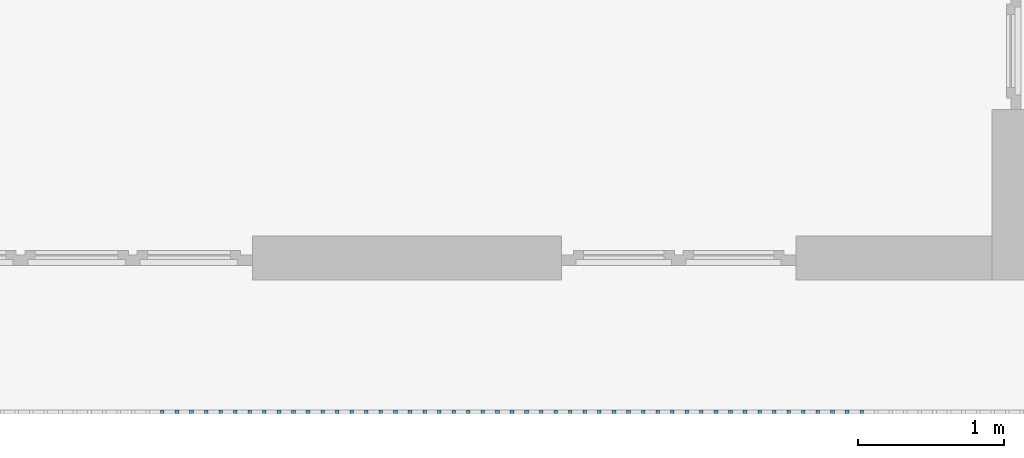
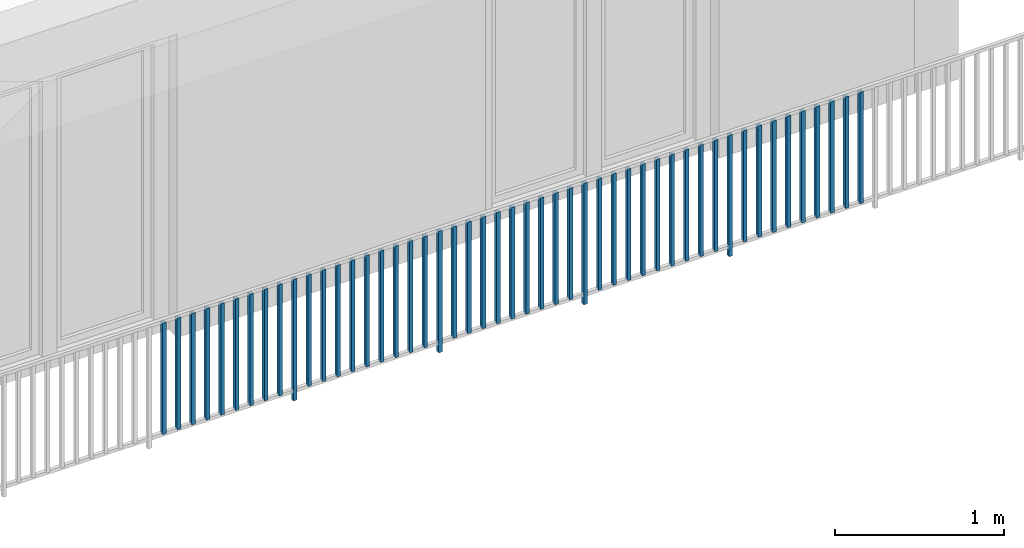
# One storey, part 36 of 48: 49 building element parts, 1 element without a shape of its own.
"""IFC4 building model written with IfcOpenShell, lengths in metres."""

from ifc_helpers import new_model, entity, si_unit, converted_unit, derived_unit, direction, frame, origin_with_axes, place, context, subcontext, project, spatial, polygons, material, type_object, element, aggregate, save


model = new_model("IFC4")

# Units and contexts
model_context = context("Model", 3, precision=1e-05, world=origin_with_axes(), true_north=direction((0.0, 1.0)))
body_context = subcontext(model_context, "Body", "Model", "MODEL_VIEW")
ifc_project = project(units=[si_unit("LENGTHUNIT", "METRE"), si_unit("AREAUNIT", "SQUARE_METRE"), si_unit("VOLUMEUNIT", "CUBIC_METRE"), converted_unit("PLANEANGLEUNIT", "DEGREE", entity("IfcPlaneAngleMeasure", 0.0174532925199), si_unit("PLANEANGLEUNIT", "RADIAN"), dimensions=[0, 0, 0, 0, 0, 0, 0]), converted_unit("TIMEUNIT", "Year", entity("IfcTimeMeasure", 31556926.0), si_unit("TIMEUNIT", "SECOND"), dimensions=[0, 0, 1, 0, 0, 0, 0]), si_unit("MASSUNIT", "GRAM", prefix="KILO"), si_unit("THERMODYNAMICTEMPERATUREUNIT", "DEGREE_CELSIUS"), si_unit("LUMINOUSINTENSITYUNIT", "LUMEN"), si_unit("ENERGYUNIT", "JOULE", prefix="MEGA"), derived_unit("THERMALCONDUCTANCEUNIT", [(si_unit("POWERUNIT", "WATT"), 1), (si_unit("LENGTHUNIT", "METRE"), -1), (si_unit("THERMODYNAMICTEMPERATUREUNIT", "KELVIN"), -1)]), derived_unit("SPECIFICHEATCAPACITYUNIT", [(si_unit("ENERGYUNIT", "JOULE"), 1), (si_unit("MASSUNIT", "GRAM", prefix="KILO"), -1), (si_unit("THERMODYNAMICTEMPERATUREUNIT", "KELVIN"), -1)]), derived_unit("MASSDENSITYUNIT", [(si_unit("MASSUNIT", "GRAM", prefix="KILO"), 1), (si_unit("VOLUMEUNIT", "CUBIC_METRE"), -1)])], contexts=[model_context])

# Site, building, storey
site_placement = place(None, origin_with_axes())
site = spatial("IfcSite", under=ifc_project, at=site_placement, CompositionType="ELEMENT")
building_placement = place(site_placement, origin_with_axes())
building = spatial("IfcBuilding", under=site, at=building_placement, CompositionType="ELEMENT")
storey_placement = place(building_placement, frame((0.0, 0.0, 3.4), z_axis=(0.0, 0.0, 1.0), x_axis=(1.0, 0.0, 0.0)))
storey = spatial("IfcBuildingStorey", under=building, at=storey_placement, Name="1. Geschoss", CompositionType="ELEMENT", Elevation=3.4)

# Railing, building element parts
railing_type = type_object("IfcRailingType", PredefinedType="NOTDEFINED")
railing_placement = place(storey_placement, frame((10.2378006196, 9.82118776896, 0.0), z_axis=(0.0, 0.0, 1.0), x_axis=(1.0, 0.0, 0.0)))
railing = element("IfcRailing", 1, at=railing_placement, inside=storey, type_object=railing_type, PredefinedType="NOTDEFINED")
ifc_material = material()
building_element_part_1_placement = place(railing_placement, origin_with_axes())
building_element_part_1 = element("IfcBuildingElementPart", 2, at=building_element_part_1_placement, material=ifc_material, PredefinedType="NOTDEFINED", context=body_context, shape_type="Tessellation", body=[
    polygons([(-6.8515, -20.6625, 0.07), (-6.8515, -20.6375, 0.07), (-6.8515, -20.6375, 0.8775), (-6.8515, -20.6625, 0.8775), (-6.8765, -20.6625, 0.07), (-6.8765, -20.6375, 0.07), (-6.8765, -20.6375, 0.8775), (-6.8765, -20.6625, 0.8775)], [[[1, 2, 3, 4]], [[1, 5, 6, 2]], [[2, 6, 7, 3]], [[4, 3, 7, 8]], [[5, 1, 4, 8]], [[6, 5, 8, 7]]], closed=True),
])
building_element_part_2_placement = place(railing_placement, origin_with_axes())
building_element_part_2 = element("IfcBuildingElementPart", 3, at=building_element_part_2_placement, material=ifc_material, PredefinedType="NOTDEFINED", context=body_context, shape_type="Tessellation", body=[
    polygons([(-6.75202173913, -20.6625, 0.07), (-6.75202173913, -20.6375, 0.07), (-6.75202173913, -20.6375, 0.8775), (-6.75202173913, -20.6625, 0.8775), (-6.77702173913, -20.6625, 0.07), (-6.77702173913, -20.6375, 0.07), (-6.77702173913, -20.6375, 0.8775), (-6.77702173913, -20.6625, 0.8775)], [[[1, 2, 3, 4]], [[1, 5, 6, 2]], [[2, 6, 7, 3]], [[4, 3, 7, 8]], [[5, 1, 4, 8]], [[6, 5, 8, 7]]], closed=True),
])
building_element_part_3_placement = place(railing_placement, origin_with_axes())
building_element_part_3 = element("IfcBuildingElementPart", 4, at=building_element_part_3_placement, material=ifc_material, PredefinedType="NOTDEFINED", context=body_context, shape_type="Tessellation", body=[
    polygons([(-6.65254347826, -20.6625, 0.07), (-6.65254347826, -20.6375, 0.07), (-6.65254347826, -20.6375, 0.8775), (-6.65254347826, -20.6625, 0.8775), (-6.67754347826, -20.6625, 0.07), (-6.67754347826, -20.6375, 0.07), (-6.67754347826, -20.6375, 0.8775), (-6.67754347826, -20.6625, 0.8775)], [[[1, 2, 3, 4]], [[1, 5, 6, 2]], [[2, 6, 7, 3]], [[4, 3, 7, 8]], [[5, 1, 4, 8]], [[6, 5, 8, 7]]], closed=True),
])
building_element_part_4_placement = place(railing_placement, origin_with_axes())
building_element_part_4 = element("IfcBuildingElementPart", 5, at=building_element_part_4_placement, material=ifc_material, PredefinedType="NOTDEFINED", context=body_context, shape_type="Tessellation", body=[
    polygons([(-6.55306521739, -20.6625, 0.07), (-6.55306521739, -20.6375, 0.07), (-6.55306521739, -20.6375, 0.8775), (-6.55306521739, -20.6625, 0.8775), (-6.57806521739, -20.6625, 0.07), (-6.57806521739, -20.6375, 0.07), (-6.57806521739, -20.6375, 0.8775), (-6.57806521739, -20.6625, 0.8775)], [[[1, 2, 3, 4]], [[1, 5, 6, 2]], [[2, 6, 7, 3]], [[4, 3, 7, 8]], [[5, 1, 4, 8]], [[6, 5, 8, 7]]], closed=True),
])
building_element_part_5_placement = place(railing_placement, origin_with_axes())
building_element_part_5 = element("IfcBuildingElementPart", 6, at=building_element_part_5_placement, material=ifc_material, PredefinedType="NOTDEFINED", context=body_context, shape_type="Tessellation", body=[
    polygons([(-6.45358695652, -20.6625, 0.07), (-6.45358695652, -20.6375, 0.07), (-6.45358695652, -20.6375, 0.8775), (-6.45358695652, -20.6625, 0.8775), (-6.47858695652, -20.6625, 0.07), (-6.47858695652, -20.6375, 0.07), (-6.47858695652, -20.6375, 0.8775), (-6.47858695652, -20.6625, 0.8775)], [[[1, 2, 3, 4]], [[1, 5, 6, 2]], [[2, 6, 7, 3]], [[4, 3, 7, 8]], [[5, 1, 4, 8]], [[6, 5, 8, 7]]], closed=True),
])
building_element_part_6_placement = place(railing_placement, origin_with_axes())
building_element_part_6 = element("IfcBuildingElementPart", 7, at=building_element_part_6_placement, material=ifc_material, PredefinedType="NOTDEFINED", context=body_context, shape_type="Tessellation", body=[
    polygons([(-6.35410869565, -20.6625, 0.07), (-6.35410869565, -20.6375, 0.07), (-6.35410869565, -20.6375, 0.8775), (-6.35410869565, -20.6625, 0.8775), (-6.37910869565, -20.6625, 0.07), (-6.37910869565, -20.6375, 0.07), (-6.37910869565, -20.6375, 0.8775), (-6.37910869565, -20.6625, 0.8775)], [[[1, 2, 3, 4]], [[1, 5, 6, 2]], [[2, 6, 7, 3]], [[4, 3, 7, 8]], [[5, 1, 4, 8]], [[6, 5, 8, 7]]], closed=True),
])
building_element_part_7_placement = place(railing_placement, origin_with_axes())
building_element_part_7 = element("IfcBuildingElementPart", 8, at=building_element_part_7_placement, material=ifc_material, PredefinedType="NOTDEFINED", context=body_context, shape_type="Tessellation", body=[
    polygons([(-6.25463043478, -20.6625, 0.07), (-6.25463043478, -20.6375, 0.07), (-6.25463043478, -20.6375, 0.8775), (-6.25463043478, -20.6625, 0.8775), (-6.27963043478, -20.6625, 0.07), (-6.27963043478, -20.6375, 0.07), (-6.27963043478, -20.6375, 0.8775), (-6.27963043478, -20.6625, 0.8775)], [[[1, 2, 3, 4]], [[1, 5, 6, 2]], [[2, 6, 7, 3]], [[4, 3, 7, 8]], [[5, 1, 4, 8]], [[6, 5, 8, 7]]], closed=True),
])
building_element_part_8_placement = place(railing_placement, origin_with_axes())
building_element_part_8 = element("IfcBuildingElementPart", 9, at=building_element_part_8_placement, material=ifc_material, PredefinedType="NOTDEFINED", context=body_context, shape_type="Tessellation", body=[
    polygons([(-6.15515217391, -20.6625, 0.07), (-6.15515217391, -20.6375, 0.07), (-6.15515217391, -20.6375, 0.8775), (-6.15515217391, -20.6625, 0.8775), (-6.18015217391, -20.6625, 0.07), (-6.18015217391, -20.6375, 0.07), (-6.18015217391, -20.6375, 0.8775), (-6.18015217391, -20.6625, 0.8775)], [[[1, 2, 3, 4]], [[1, 5, 6, 2]], [[2, 6, 7, 3]], [[4, 3, 7, 8]], [[5, 1, 4, 8]], [[6, 5, 8, 7]]], closed=True),
])
building_element_part_9_placement = place(railing_placement, origin_with_axes())
building_element_part_9 = element("IfcBuildingElementPart", 10, at=building_element_part_9_placement, material=ifc_material, PredefinedType="NOTDEFINED", context=body_context, shape_type="Tessellation", body=[
    polygons([(-6.05567391304, -20.6625, 0.07), (-6.05567391304, -20.6375, 0.07), (-6.05567391304, -20.6375, 0.8775), (-6.05567391304, -20.6625, 0.8775), (-6.08067391304, -20.6625, 0.07), (-6.08067391304, -20.6375, 0.07), (-6.08067391304, -20.6375, 0.8775), (-6.08067391304, -20.6625, 0.8775)], [[[1, 2, 3, 4]], [[1, 5, 6, 2]], [[2, 6, 7, 3]], [[4, 3, 7, 8]], [[5, 1, 4, 8]], [[6, 5, 8, 7]]], closed=True),
])
building_element_part_10_placement = place(railing_placement, origin_with_axes())
building_element_part_10 = element("IfcBuildingElementPart", 11, at=building_element_part_10_placement, material=ifc_material, PredefinedType="NOTDEFINED", context=body_context, shape_type="Tessellation", body=[
    polygons([(-5.95619565217, -20.6625, 0.0), (-5.95619565217, -20.6375, 0.0), (-5.95619565217, -20.6375, 0.88), (-5.95619565217, -20.6625, 0.88), (-5.98119565217, -20.6625, 0.0), (-5.98119565217, -20.6375, 0.0), (-5.98119565217, -20.6375, 0.88), (-5.98119565217, -20.6625, 0.88)], [[[1, 2, 3, 4]], [[1, 5, 6, 2]], [[2, 6, 7, 3]], [[4, 3, 7, 8]], [[5, 1, 4, 8]], [[6, 5, 8, 7]]], closed=True),
])
building_element_part_11_placement = place(railing_placement, origin_with_axes())
building_element_part_11 = element("IfcBuildingElementPart", 12, at=building_element_part_11_placement, material=ifc_material, PredefinedType="NOTDEFINED", context=body_context, shape_type="Tessellation", body=[
    polygons([(-5.8567173913, -20.6625, 0.07), (-5.8567173913, -20.6375, 0.07), (-5.8567173913, -20.6375, 0.8775), (-5.8567173913, -20.6625, 0.8775), (-5.8817173913, -20.6625, 0.07), (-5.8817173913, -20.6375, 0.07), (-5.8817173913, -20.6375, 0.8775), (-5.8817173913, -20.6625, 0.8775)], [[[1, 2, 3, 4]], [[1, 5, 6, 2]], [[2, 6, 7, 3]], [[4, 3, 7, 8]], [[5, 1, 4, 8]], [[6, 5, 8, 7]]], closed=True),
])
building_element_part_12_placement = place(railing_placement, origin_with_axes())
building_element_part_12 = element("IfcBuildingElementPart", 13, at=building_element_part_12_placement, material=ifc_material, PredefinedType="NOTDEFINED", context=body_context, shape_type="Tessellation", body=[
    polygons([(-5.75723913043, -20.6625, 0.07), (-5.75723913043, -20.6375, 0.07), (-5.75723913043, -20.6375, 0.8775), (-5.75723913043, -20.6625, 0.8775), (-5.78223913043, -20.6625, 0.07), (-5.78223913043, -20.6375, 0.07), (-5.78223913043, -20.6375, 0.8775), (-5.78223913043, -20.6625, 0.8775)], [[[1, 2, 3, 4]], [[1, 5, 6, 2]], [[2, 6, 7, 3]], [[4, 3, 7, 8]], [[5, 1, 4, 8]], [[6, 5, 8, 7]]], closed=True),
])
building_element_part_13_placement = place(railing_placement, origin_with_axes())
building_element_part_13 = element("IfcBuildingElementPart", 14, at=building_element_part_13_placement, material=ifc_material, PredefinedType="NOTDEFINED", context=body_context, shape_type="Tessellation", body=[
    polygons([(-5.65776086957, -20.6625, 0.07), (-5.65776086957, -20.6375, 0.07), (-5.65776086957, -20.6375, 0.8775), (-5.65776086957, -20.6625, 0.8775), (-5.68276086957, -20.6625, 0.07), (-5.68276086957, -20.6375, 0.07), (-5.68276086957, -20.6375, 0.8775), (-5.68276086957, -20.6625, 0.8775)], [[[1, 2, 3, 4]], [[1, 5, 6, 2]], [[2, 6, 7, 3]], [[4, 3, 7, 8]], [[5, 1, 4, 8]], [[6, 5, 8, 7]]], closed=True),
])
building_element_part_14_placement = place(railing_placement, origin_with_axes())
building_element_part_14 = element("IfcBuildingElementPart", 15, at=building_element_part_14_placement, material=ifc_material, PredefinedType="NOTDEFINED", context=body_context, shape_type="Tessellation", body=[
    polygons([(-5.5582826087, -20.6625, 0.07), (-5.5582826087, -20.6375, 0.07), (-5.5582826087, -20.6375, 0.8775), (-5.5582826087, -20.6625, 0.8775), (-5.5832826087, -20.6625, 0.07), (-5.5832826087, -20.6375, 0.07), (-5.5832826087, -20.6375, 0.8775), (-5.5832826087, -20.6625, 0.8775)], [[[1, 2, 3, 4]], [[1, 5, 6, 2]], [[2, 6, 7, 3]], [[4, 3, 7, 8]], [[5, 1, 4, 8]], [[6, 5, 8, 7]]], closed=True),
])
building_element_part_15_placement = place(railing_placement, origin_with_axes())
building_element_part_15 = element("IfcBuildingElementPart", 16, at=building_element_part_15_placement, material=ifc_material, PredefinedType="NOTDEFINED", context=body_context, shape_type="Tessellation", body=[
    polygons([(-5.45880434783, -20.6625, 0.07), (-5.45880434783, -20.6375, 0.07), (-5.45880434783, -20.6375, 0.8775), (-5.45880434783, -20.6625, 0.8775), (-5.48380434783, -20.6625, 0.07), (-5.48380434783, -20.6375, 0.07), (-5.48380434783, -20.6375, 0.8775), (-5.48380434783, -20.6625, 0.8775)], [[[1, 2, 3, 4]], [[1, 5, 6, 2]], [[2, 6, 7, 3]], [[4, 3, 7, 8]], [[5, 1, 4, 8]], [[6, 5, 8, 7]]], closed=True),
])
building_element_part_16_placement = place(railing_placement, origin_with_axes())
building_element_part_16 = element("IfcBuildingElementPart", 17, at=building_element_part_16_placement, material=ifc_material, PredefinedType="NOTDEFINED", context=body_context, shape_type="Tessellation", body=[
    polygons([(-5.35932608696, -20.6625, 0.07), (-5.35932608696, -20.6375, 0.07), (-5.35932608696, -20.6375, 0.8775), (-5.35932608696, -20.6625, 0.8775), (-5.38432608696, -20.6625, 0.07), (-5.38432608696, -20.6375, 0.07), (-5.38432608696, -20.6375, 0.8775), (-5.38432608696, -20.6625, 0.8775)], [[[1, 2, 3, 4]], [[1, 5, 6, 2]], [[2, 6, 7, 3]], [[4, 3, 7, 8]], [[5, 1, 4, 8]], [[6, 5, 8, 7]]], closed=True),
])
building_element_part_17_placement = place(railing_placement, origin_with_axes())
building_element_part_17 = element("IfcBuildingElementPart", 18, at=building_element_part_17_placement, material=ifc_material, PredefinedType="NOTDEFINED", context=body_context, shape_type="Tessellation", body=[
    polygons([(-5.25984782609, -20.6625, 0.07), (-5.25984782609, -20.6375, 0.07), (-5.25984782609, -20.6375, 0.8775), (-5.25984782609, -20.6625, 0.8775), (-5.28484782609, -20.6625, 0.07), (-5.28484782609, -20.6375, 0.07), (-5.28484782609, -20.6375, 0.8775), (-5.28484782609, -20.6625, 0.8775)], [[[1, 2, 3, 4]], [[1, 5, 6, 2]], [[2, 6, 7, 3]], [[4, 3, 7, 8]], [[5, 1, 4, 8]], [[6, 5, 8, 7]]], closed=True),
])
building_element_part_18_placement = place(railing_placement, origin_with_axes())
building_element_part_18 = element("IfcBuildingElementPart", 19, at=building_element_part_18_placement, material=ifc_material, PredefinedType="NOTDEFINED", context=body_context, shape_type="Tessellation", body=[
    polygons([(-5.16036956522, -20.6625, 0.07), (-5.16036956522, -20.6375, 0.07), (-5.16036956522, -20.6375, 0.8775), (-5.16036956522, -20.6625, 0.8775), (-5.18536956522, -20.6625, 0.07), (-5.18536956522, -20.6375, 0.07), (-5.18536956522, -20.6375, 0.8775), (-5.18536956522, -20.6625, 0.8775)], [[[1, 2, 3, 4]], [[1, 5, 6, 2]], [[2, 6, 7, 3]], [[4, 3, 7, 8]], [[5, 1, 4, 8]], [[6, 5, 8, 7]]], closed=True),
])
building_element_part_19_placement = place(railing_placement, origin_with_axes())
building_element_part_19 = element("IfcBuildingElementPart", 20, at=building_element_part_19_placement, material=ifc_material, PredefinedType="NOTDEFINED", context=body_context, shape_type="Tessellation", body=[
    polygons([(-5.06089130435, -20.6625, 0.07), (-5.06089130435, -20.6375, 0.07), (-5.06089130435, -20.6375, 0.8775), (-5.06089130435, -20.6625, 0.8775), (-5.08589130435, -20.6625, 0.07), (-5.08589130435, -20.6375, 0.07), (-5.08589130435, -20.6375, 0.8775), (-5.08589130435, -20.6625, 0.8775)], [[[1, 2, 3, 4]], [[1, 5, 6, 2]], [[2, 6, 7, 3]], [[4, 3, 7, 8]], [[5, 1, 4, 8]], [[6, 5, 8, 7]]], closed=True),
])
building_element_part_20_placement = place(railing_placement, origin_with_axes())
building_element_part_20 = element("IfcBuildingElementPart", 21, at=building_element_part_20_placement, material=ifc_material, PredefinedType="NOTDEFINED", context=body_context, shape_type="Tessellation", body=[
    polygons([(-4.96141304348, -20.6625, 0.0), (-4.96141304348, -20.6375, 0.0), (-4.96141304348, -20.6375, 0.88), (-4.96141304348, -20.6625, 0.88), (-4.98641304348, -20.6625, 0.0), (-4.98641304348, -20.6375, 0.0), (-4.98641304348, -20.6375, 0.88), (-4.98641304348, -20.6625, 0.88)], [[[1, 2, 3, 4]], [[1, 5, 6, 2]], [[2, 6, 7, 3]], [[4, 3, 7, 8]], [[5, 1, 4, 8]], [[6, 5, 8, 7]]], closed=True),
])
building_element_part_21_placement = place(railing_placement, origin_with_axes())
building_element_part_21 = element("IfcBuildingElementPart", 22, at=building_element_part_21_placement, material=ifc_material, PredefinedType="NOTDEFINED", context=body_context, shape_type="Tessellation", body=[
    polygons([(-4.86193478261, -20.6625, 0.07), (-4.86193478261, -20.6375, 0.07), (-4.86193478261, -20.6375, 0.8775), (-4.86193478261, -20.6625, 0.8775), (-4.88693478261, -20.6625, 0.07), (-4.88693478261, -20.6375, 0.07), (-4.88693478261, -20.6375, 0.8775), (-4.88693478261, -20.6625, 0.8775)], [[[1, 2, 3, 4]], [[1, 5, 6, 2]], [[2, 6, 7, 3]], [[4, 3, 7, 8]], [[5, 1, 4, 8]], [[6, 5, 8, 7]]], closed=True),
])
building_element_part_22_placement = place(railing_placement, origin_with_axes())
building_element_part_22 = element("IfcBuildingElementPart", 23, at=building_element_part_22_placement, material=ifc_material, PredefinedType="NOTDEFINED", context=body_context, shape_type="Tessellation", body=[
    polygons([(-4.76245652174, -20.6625, 0.07), (-4.76245652174, -20.6375, 0.07), (-4.76245652174, -20.6375, 0.8775), (-4.76245652174, -20.6625, 0.8775), (-4.78745652174, -20.6625, 0.07), (-4.78745652174, -20.6375, 0.07), (-4.78745652174, -20.6375, 0.8775), (-4.78745652174, -20.6625, 0.8775)], [[[1, 2, 3, 4]], [[1, 5, 6, 2]], [[2, 6, 7, 3]], [[4, 3, 7, 8]], [[5, 1, 4, 8]], [[6, 5, 8, 7]]], closed=True),
])
building_element_part_23_placement = place(railing_placement, origin_with_axes())
building_element_part_23 = element("IfcBuildingElementPart", 24, at=building_element_part_23_placement, material=ifc_material, PredefinedType="NOTDEFINED", context=body_context, shape_type="Tessellation", body=[
    polygons([(-4.66297826087, -20.6625, 0.07), (-4.66297826087, -20.6375, 0.07), (-4.66297826087, -20.6375, 0.8775), (-4.66297826087, -20.6625, 0.8775), (-4.68797826087, -20.6625, 0.07), (-4.68797826087, -20.6375, 0.07), (-4.68797826087, -20.6375, 0.8775), (-4.68797826087, -20.6625, 0.8775)], [[[1, 2, 3, 4]], [[1, 5, 6, 2]], [[2, 6, 7, 3]], [[4, 3, 7, 8]], [[5, 1, 4, 8]], [[6, 5, 8, 7]]], closed=True),
])
building_element_part_24_placement = place(railing_placement, origin_with_axes())
building_element_part_24 = element("IfcBuildingElementPart", 25, at=building_element_part_24_placement, material=ifc_material, PredefinedType="NOTDEFINED", context=body_context, shape_type="Tessellation", body=[
    polygons([(-4.5635, -20.6625, 0.07), (-4.5635, -20.6375, 0.07), (-4.5635, -20.6375, 0.8775), (-4.5635, -20.6625, 0.8775), (-4.5885, -20.6625, 0.07), (-4.5885, -20.6375, 0.07), (-4.5885, -20.6375, 0.8775), (-4.5885, -20.6625, 0.8775)], [[[1, 2, 3, 4]], [[1, 5, 6, 2]], [[2, 6, 7, 3]], [[4, 3, 7, 8]], [[5, 1, 4, 8]], [[6, 5, 8, 7]]], closed=True),
])
building_element_part_25_placement = place(railing_placement, origin_with_axes())
building_element_part_25 = element("IfcBuildingElementPart", 26, at=building_element_part_25_placement, material=ifc_material, PredefinedType="NOTDEFINED", context=body_context, shape_type="Tessellation", body=[
    polygons([(-4.46402173913, -20.6625, 0.07), (-4.46402173913, -20.6375, 0.07), (-4.46402173913, -20.6375, 0.8775), (-4.46402173913, -20.6625, 0.8775), (-4.48902173913, -20.6625, 0.07), (-4.48902173913, -20.6375, 0.07), (-4.48902173913, -20.6375, 0.8775), (-4.48902173913, -20.6625, 0.8775)], [[[1, 2, 3, 4]], [[1, 5, 6, 2]], [[2, 6, 7, 3]], [[4, 3, 7, 8]], [[5, 1, 4, 8]], [[6, 5, 8, 7]]], closed=True),
])
building_element_part_26_placement = place(railing_placement, origin_with_axes())
building_element_part_26 = element("IfcBuildingElementPart", 27, at=building_element_part_26_placement, material=ifc_material, PredefinedType="NOTDEFINED", context=body_context, shape_type="Tessellation", body=[
    polygons([(-4.36454347826, -20.6625, 0.07), (-4.36454347826, -20.6375, 0.07), (-4.36454347826, -20.6375, 0.8775), (-4.36454347826, -20.6625, 0.8775), (-4.38954347826, -20.6625, 0.07), (-4.38954347826, -20.6375, 0.07), (-4.38954347826, -20.6375, 0.8775), (-4.38954347826, -20.6625, 0.8775)], [[[1, 2, 3, 4]], [[1, 5, 6, 2]], [[2, 6, 7, 3]], [[4, 3, 7, 8]], [[5, 1, 4, 8]], [[6, 5, 8, 7]]], closed=True),
])
building_element_part_27_placement = place(railing_placement, origin_with_axes())
building_element_part_27 = element("IfcBuildingElementPart", 28, at=building_element_part_27_placement, material=ifc_material, PredefinedType="NOTDEFINED", context=body_context, shape_type="Tessellation", body=[
    polygons([(-4.26506521739, -20.6625, 0.07), (-4.26506521739, -20.6375, 0.07), (-4.26506521739, -20.6375, 0.8775), (-4.26506521739, -20.6625, 0.8775), (-4.29006521739, -20.6625, 0.07), (-4.29006521739, -20.6375, 0.07), (-4.29006521739, -20.6375, 0.8775), (-4.29006521739, -20.6625, 0.8775)], [[[1, 2, 3, 4]], [[1, 5, 6, 2]], [[2, 6, 7, 3]], [[4, 3, 7, 8]], [[5, 1, 4, 8]], [[6, 5, 8, 7]]], closed=True),
])
building_element_part_28_placement = place(railing_placement, origin_with_axes())
building_element_part_28 = element("IfcBuildingElementPart", 29, at=building_element_part_28_placement, material=ifc_material, PredefinedType="NOTDEFINED", context=body_context, shape_type="Tessellation", body=[
    polygons([(-4.16558695652, -20.6625, 0.07), (-4.16558695652, -20.6375, 0.07), (-4.16558695652, -20.6375, 0.8775), (-4.16558695652, -20.6625, 0.8775), (-4.19058695652, -20.6625, 0.07), (-4.19058695652, -20.6375, 0.07), (-4.19058695652, -20.6375, 0.8775), (-4.19058695652, -20.6625, 0.8775)], [[[1, 2, 3, 4]], [[1, 5, 6, 2]], [[2, 6, 7, 3]], [[4, 3, 7, 8]], [[5, 1, 4, 8]], [[6, 5, 8, 7]]], closed=True),
])
building_element_part_29_placement = place(railing_placement, origin_with_axes())
building_element_part_29 = element("IfcBuildingElementPart", 30, at=building_element_part_29_placement, material=ifc_material, PredefinedType="NOTDEFINED", context=body_context, shape_type="Tessellation", body=[
    polygons([(-4.06610869565, -20.6625, 0.07), (-4.06610869565, -20.6375, 0.07), (-4.06610869565, -20.6375, 0.8775), (-4.06610869565, -20.6625, 0.8775), (-4.09110869565, -20.6625, 0.07), (-4.09110869565, -20.6375, 0.07), (-4.09110869565, -20.6375, 0.8775), (-4.09110869565, -20.6625, 0.8775)], [[[1, 2, 3, 4]], [[1, 5, 6, 2]], [[2, 6, 7, 3]], [[4, 3, 7, 8]], [[5, 1, 4, 8]], [[6, 5, 8, 7]]], closed=True),
])
building_element_part_30_placement = place(railing_placement, origin_with_axes())
building_element_part_30 = element("IfcBuildingElementPart", 31, at=building_element_part_30_placement, material=ifc_material, PredefinedType="NOTDEFINED", context=body_context, shape_type="Tessellation", body=[
    polygons([(-3.96663043478, -20.6625, 0.0), (-3.96663043478, -20.6375, 0.0), (-3.96663043478, -20.6375, 0.88), (-3.96663043478, -20.6625, 0.88), (-3.99163043478, -20.6625, 0.0), (-3.99163043478, -20.6375, 0.0), (-3.99163043478, -20.6375, 0.88), (-3.99163043478, -20.6625, 0.88)], [[[1, 2, 3, 4]], [[1, 5, 6, 2]], [[2, 6, 7, 3]], [[4, 3, 7, 8]], [[5, 1, 4, 8]], [[6, 5, 8, 7]]], closed=True),
])
building_element_part_31_placement = place(railing_placement, origin_with_axes())
building_element_part_31 = element("IfcBuildingElementPart", 32, at=building_element_part_31_placement, material=ifc_material, PredefinedType="NOTDEFINED", context=body_context, shape_type="Tessellation", body=[
    polygons([(-3.86715217391, -20.6625, 0.07), (-3.86715217391, -20.6375, 0.07), (-3.86715217391, -20.6375, 0.8775), (-3.86715217391, -20.6625, 0.8775), (-3.89215217391, -20.6625, 0.07), (-3.89215217391, -20.6375, 0.07), (-3.89215217391, -20.6375, 0.8775), (-3.89215217391, -20.6625, 0.8775)], [[[1, 2, 3, 4]], [[1, 5, 6, 2]], [[2, 6, 7, 3]], [[4, 3, 7, 8]], [[5, 1, 4, 8]], [[6, 5, 8, 7]]], closed=True),
])
building_element_part_32_placement = place(railing_placement, origin_with_axes())
building_element_part_32 = element("IfcBuildingElementPart", 33, at=building_element_part_32_placement, material=ifc_material, PredefinedType="NOTDEFINED", context=body_context, shape_type="Tessellation", body=[
    polygons([(-3.76767391304, -20.6625, 0.07), (-3.76767391304, -20.6375, 0.07), (-3.76767391304, -20.6375, 0.8775), (-3.76767391304, -20.6625, 0.8775), (-3.79267391304, -20.6625, 0.07), (-3.79267391304, -20.6375, 0.07), (-3.79267391304, -20.6375, 0.8775), (-3.79267391304, -20.6625, 0.8775)], [[[1, 2, 3, 4]], [[1, 5, 6, 2]], [[2, 6, 7, 3]], [[4, 3, 7, 8]], [[5, 1, 4, 8]], [[6, 5, 8, 7]]], closed=True),
])
building_element_part_33_placement = place(railing_placement, origin_with_axes())
building_element_part_33 = element("IfcBuildingElementPart", 34, at=building_element_part_33_placement, material=ifc_material, PredefinedType="NOTDEFINED", context=body_context, shape_type="Tessellation", body=[
    polygons([(-3.66819565217, -20.6625, 0.07), (-3.66819565217, -20.6375, 0.07), (-3.66819565217, -20.6375, 0.8775), (-3.66819565217, -20.6625, 0.8775), (-3.69319565217, -20.6625, 0.07), (-3.69319565217, -20.6375, 0.07), (-3.69319565217, -20.6375, 0.8775), (-3.69319565217, -20.6625, 0.8775)], [[[1, 2, 3, 4]], [[1, 5, 6, 2]], [[2, 6, 7, 3]], [[4, 3, 7, 8]], [[5, 1, 4, 8]], [[6, 5, 8, 7]]], closed=True),
])
building_element_part_34_placement = place(railing_placement, origin_with_axes())
building_element_part_34 = element("IfcBuildingElementPart", 35, at=building_element_part_34_placement, material=ifc_material, PredefinedType="NOTDEFINED", context=body_context, shape_type="Tessellation", body=[
    polygons([(-3.5687173913, -20.6625, 0.07), (-3.5687173913, -20.6375, 0.07), (-3.5687173913, -20.6375, 0.8775), (-3.5687173913, -20.6625, 0.8775), (-3.5937173913, -20.6625, 0.07), (-3.5937173913, -20.6375, 0.07), (-3.5937173913, -20.6375, 0.8775), (-3.5937173913, -20.6625, 0.8775)], [[[1, 2, 3, 4]], [[1, 5, 6, 2]], [[2, 6, 7, 3]], [[4, 3, 7, 8]], [[5, 1, 4, 8]], [[6, 5, 8, 7]]], closed=True),
])
building_element_part_35_placement = place(railing_placement, origin_with_axes())
building_element_part_35 = element("IfcBuildingElementPart", 36, at=building_element_part_35_placement, material=ifc_material, PredefinedType="NOTDEFINED", context=body_context, shape_type="Tessellation", body=[
    polygons([(-3.46923913043, -20.6625, 0.07), (-3.46923913043, -20.6375, 0.07), (-3.46923913043, -20.6375, 0.8775), (-3.46923913043, -20.6625, 0.8775), (-3.49423913043, -20.6625, 0.07), (-3.49423913043, -20.6375, 0.07), (-3.49423913043, -20.6375, 0.8775), (-3.49423913043, -20.6625, 0.8775)], [[[1, 2, 3, 4]], [[1, 5, 6, 2]], [[2, 6, 7, 3]], [[4, 3, 7, 8]], [[5, 1, 4, 8]], [[6, 5, 8, 7]]], closed=True),
])
building_element_part_36_placement = place(railing_placement, origin_with_axes())
building_element_part_36 = element("IfcBuildingElementPart", 37, at=building_element_part_36_placement, material=ifc_material, PredefinedType="NOTDEFINED", context=body_context, shape_type="Tessellation", body=[
    polygons([(-3.36976086957, -20.6625, 0.07), (-3.36976086957, -20.6375, 0.07), (-3.36976086957, -20.6375, 0.8775), (-3.36976086957, -20.6625, 0.8775), (-3.39476086957, -20.6625, 0.07), (-3.39476086957, -20.6375, 0.07), (-3.39476086957, -20.6375, 0.8775), (-3.39476086957, -20.6625, 0.8775)], [[[1, 2, 3, 4]], [[1, 5, 6, 2]], [[2, 6, 7, 3]], [[4, 3, 7, 8]], [[5, 1, 4, 8]], [[6, 5, 8, 7]]], closed=True),
])
building_element_part_37_placement = place(railing_placement, origin_with_axes())
building_element_part_37 = element("IfcBuildingElementPart", 38, at=building_element_part_37_placement, material=ifc_material, PredefinedType="NOTDEFINED", context=body_context, shape_type="Tessellation", body=[
    polygons([(-3.2702826087, -20.6625, 0.07), (-3.2702826087, -20.6375, 0.07), (-3.2702826087, -20.6375, 0.8775), (-3.2702826087, -20.6625, 0.8775), (-3.2952826087, -20.6625, 0.07), (-3.2952826087, -20.6375, 0.07), (-3.2952826087, -20.6375, 0.8775), (-3.2952826087, -20.6625, 0.8775)], [[[1, 2, 3, 4]], [[1, 5, 6, 2]], [[2, 6, 7, 3]], [[4, 3, 7, 8]], [[5, 1, 4, 8]], [[6, 5, 8, 7]]], closed=True),
])
building_element_part_38_placement = place(railing_placement, origin_with_axes())
building_element_part_38 = element("IfcBuildingElementPart", 39, at=building_element_part_38_placement, material=ifc_material, PredefinedType="NOTDEFINED", context=body_context, shape_type="Tessellation", body=[
    polygons([(-3.17080434783, -20.6625, 0.07), (-3.17080434783, -20.6375, 0.07), (-3.17080434783, -20.6375, 0.8775), (-3.17080434783, -20.6625, 0.8775), (-3.19580434783, -20.6625, 0.07), (-3.19580434783, -20.6375, 0.07), (-3.19580434783, -20.6375, 0.8775), (-3.19580434783, -20.6625, 0.8775)], [[[1, 2, 3, 4]], [[1, 5, 6, 2]], [[2, 6, 7, 3]], [[4, 3, 7, 8]], [[5, 1, 4, 8]], [[6, 5, 8, 7]]], closed=True),
])
building_element_part_39_placement = place(railing_placement, origin_with_axes())
building_element_part_39 = element("IfcBuildingElementPart", 40, at=building_element_part_39_placement, material=ifc_material, PredefinedType="NOTDEFINED", context=body_context, shape_type="Tessellation", body=[
    polygons([(-3.07132608696, -20.6625, 0.07), (-3.07132608696, -20.6375, 0.07), (-3.07132608696, -20.6375, 0.8775), (-3.07132608696, -20.6625, 0.8775), (-3.09632608696, -20.6625, 0.07), (-3.09632608696, -20.6375, 0.07), (-3.09632608696, -20.6375, 0.8775), (-3.09632608696, -20.6625, 0.8775)], [[[1, 2, 3, 4]], [[1, 5, 6, 2]], [[2, 6, 7, 3]], [[4, 3, 7, 8]], [[5, 1, 4, 8]], [[6, 5, 8, 7]]], closed=True),
])
building_element_part_40_placement = place(railing_placement, origin_with_axes())
building_element_part_40 = element("IfcBuildingElementPart", 41, at=building_element_part_40_placement, material=ifc_material, PredefinedType="NOTDEFINED", context=body_context, shape_type="Tessellation", body=[
    polygons([(-2.97184782609, -20.6625, 0.0), (-2.97184782609, -20.6375, 0.0), (-2.97184782609, -20.6375, 0.88), (-2.97184782609, -20.6625, 0.88), (-2.99684782609, -20.6625, 0.0), (-2.99684782609, -20.6375, 0.0), (-2.99684782609, -20.6375, 0.88), (-2.99684782609, -20.6625, 0.88)], [[[1, 2, 3, 4]], [[1, 5, 6, 2]], [[2, 6, 7, 3]], [[4, 3, 7, 8]], [[5, 1, 4, 8]], [[6, 5, 8, 7]]], closed=True),
])
building_element_part_41_placement = place(railing_placement, origin_with_axes())
building_element_part_41 = element("IfcBuildingElementPart", 42, at=building_element_part_41_placement, material=ifc_material, PredefinedType="NOTDEFINED", context=body_context, shape_type="Tessellation", body=[
    polygons([(-2.87236956522, -20.6625, 0.07), (-2.87236956522, -20.6375, 0.07), (-2.87236956522, -20.6375, 0.8775), (-2.87236956522, -20.6625, 0.8775), (-2.89736956522, -20.6625, 0.07), (-2.89736956522, -20.6375, 0.07), (-2.89736956522, -20.6375, 0.8775), (-2.89736956522, -20.6625, 0.8775)], [[[1, 2, 3, 4]], [[1, 5, 6, 2]], [[2, 6, 7, 3]], [[4, 3, 7, 8]], [[5, 1, 4, 8]], [[6, 5, 8, 7]]], closed=True),
])
building_element_part_42_placement = place(railing_placement, origin_with_axes())
building_element_part_42 = element("IfcBuildingElementPart", 43, at=building_element_part_42_placement, material=ifc_material, PredefinedType="NOTDEFINED", context=body_context, shape_type="Tessellation", body=[
    polygons([(-2.77289130435, -20.6625, 0.07), (-2.77289130435, -20.6375, 0.07), (-2.77289130435, -20.6375, 0.8775), (-2.77289130435, -20.6625, 0.8775), (-2.79789130435, -20.6625, 0.07), (-2.79789130435, -20.6375, 0.07), (-2.79789130435, -20.6375, 0.8775), (-2.79789130435, -20.6625, 0.8775)], [[[1, 2, 3, 4]], [[1, 5, 6, 2]], [[2, 6, 7, 3]], [[4, 3, 7, 8]], [[5, 1, 4, 8]], [[6, 5, 8, 7]]], closed=True),
])
building_element_part_43_placement = place(railing_placement, origin_with_axes())
building_element_part_43 = element("IfcBuildingElementPart", 44, at=building_element_part_43_placement, material=ifc_material, PredefinedType="NOTDEFINED", context=body_context, shape_type="Tessellation", body=[
    polygons([(-2.67341304348, -20.6625, 0.07), (-2.67341304348, -20.6375, 0.07), (-2.67341304348, -20.6375, 0.8775), (-2.67341304348, -20.6625, 0.8775), (-2.69841304348, -20.6625, 0.07), (-2.69841304348, -20.6375, 0.07), (-2.69841304348, -20.6375, 0.8775), (-2.69841304348, -20.6625, 0.8775)], [[[1, 2, 3, 4]], [[1, 5, 6, 2]], [[2, 6, 7, 3]], [[4, 3, 7, 8]], [[5, 1, 4, 8]], [[6, 5, 8, 7]]], closed=True),
])
building_element_part_44_placement = place(railing_placement, origin_with_axes())
building_element_part_44 = element("IfcBuildingElementPart", 45, at=building_element_part_44_placement, material=ifc_material, PredefinedType="NOTDEFINED", context=body_context, shape_type="Tessellation", body=[
    polygons([(-2.57393478261, -20.6625, 0.07), (-2.57393478261, -20.6375, 0.07), (-2.57393478261, -20.6375, 0.8775), (-2.57393478261, -20.6625, 0.8775), (-2.59893478261, -20.6625, 0.07), (-2.59893478261, -20.6375, 0.07), (-2.59893478261, -20.6375, 0.8775), (-2.59893478261, -20.6625, 0.8775)], [[[1, 2, 3, 4]], [[1, 5, 6, 2]], [[2, 6, 7, 3]], [[4, 3, 7, 8]], [[5, 1, 4, 8]], [[6, 5, 8, 7]]], closed=True),
])
building_element_part_45_placement = place(railing_placement, origin_with_axes())
building_element_part_45 = element("IfcBuildingElementPart", 46, at=building_element_part_45_placement, material=ifc_material, PredefinedType="NOTDEFINED", context=body_context, shape_type="Tessellation", body=[
    polygons([(-2.47445652174, -20.6625, 0.07), (-2.47445652174, -20.6375, 0.07), (-2.47445652174, -20.6375, 0.8775), (-2.47445652174, -20.6625, 0.8775), (-2.49945652174, -20.6625, 0.07), (-2.49945652174, -20.6375, 0.07), (-2.49945652174, -20.6375, 0.8775), (-2.49945652174, -20.6625, 0.8775)], [[[1, 2, 3, 4]], [[1, 5, 6, 2]], [[2, 6, 7, 3]], [[4, 3, 7, 8]], [[5, 1, 4, 8]], [[6, 5, 8, 7]]], closed=True),
])
building_element_part_46_placement = place(railing_placement, origin_with_axes())
building_element_part_46 = element("IfcBuildingElementPart", 47, at=building_element_part_46_placement, material=ifc_material, PredefinedType="NOTDEFINED", context=body_context, shape_type="Tessellation", body=[
    polygons([(-2.37497826087, -20.6625, 0.07), (-2.37497826087, -20.6375, 0.07), (-2.37497826087, -20.6375, 0.8775), (-2.37497826087, -20.6625, 0.8775), (-2.39997826087, -20.6625, 0.07), (-2.39997826087, -20.6375, 0.07), (-2.39997826087, -20.6375, 0.8775), (-2.39997826087, -20.6625, 0.8775)], [[[1, 2, 3, 4]], [[1, 5, 6, 2]], [[2, 6, 7, 3]], [[4, 3, 7, 8]], [[5, 1, 4, 8]], [[6, 5, 8, 7]]], closed=True),
])
building_element_part_47_placement = place(railing_placement, origin_with_axes())
building_element_part_47 = element("IfcBuildingElementPart", 48, at=building_element_part_47_placement, material=ifc_material, PredefinedType="NOTDEFINED", context=body_context, shape_type="Tessellation", body=[
    polygons([(-2.2755, -20.6625, 0.07), (-2.2755, -20.6375, 0.07), (-2.2755, -20.6375, 0.8775), (-2.2755, -20.6625, 0.8775), (-2.3005, -20.6625, 0.07), (-2.3005, -20.6375, 0.07), (-2.3005, -20.6375, 0.8775), (-2.3005, -20.6625, 0.8775)], [[[1, 2, 3, 4]], [[1, 5, 6, 2]], [[2, 6, 7, 3]], [[4, 3, 7, 8]], [[5, 1, 4, 8]], [[6, 5, 8, 7]]], closed=True),
])
building_element_part_48_placement = place(railing_placement, origin_with_axes())
building_element_part_48 = element("IfcBuildingElementPart", 49, at=building_element_part_48_placement, material=ifc_material, PredefinedType="NOTDEFINED", context=body_context, shape_type="Tessellation", body=[
    polygons([(-2.17602173913, -20.6625, 0.07), (-2.17602173913, -20.6375, 0.07), (-2.17602173913, -20.6375, 0.8775), (-2.17602173913, -20.6625, 0.8775), (-2.20102173913, -20.6625, 0.07), (-2.20102173913, -20.6375, 0.07), (-2.20102173913, -20.6375, 0.8775), (-2.20102173913, -20.6625, 0.8775)], [[[1, 2, 3, 4]], [[1, 5, 6, 2]], [[2, 6, 7, 3]], [[4, 3, 7, 8]], [[5, 1, 4, 8]], [[6, 5, 8, 7]]], closed=True),
])
building_element_part_49_placement = place(railing_placement, origin_with_axes())
building_element_part_49 = element("IfcBuildingElementPart", 50, at=building_element_part_49_placement, material=ifc_material, PredefinedType="NOTDEFINED", context=body_context, shape_type="Tessellation", body=[
    polygons([(-2.07654347826, -20.6625, 0.07), (-2.07654347826, -20.6375, 0.07), (-2.07654347826, -20.6375, 0.8775), (-2.07654347826, -20.6625, 0.8775), (-2.10154347826, -20.6625, 0.07), (-2.10154347826, -20.6375, 0.07), (-2.10154347826, -20.6375, 0.8775), (-2.10154347826, -20.6625, 0.8775)], [[[1, 2, 3, 4]], [[1, 5, 6, 2]], [[2, 6, 7, 3]], [[4, 3, 7, 8]], [[5, 1, 4, 8]], [[6, 5, 8, 7]]], closed=True),
])
aggregate(railing, [building_element_part_1, building_element_part_2, building_element_part_3, building_element_part_4, building_element_part_5, building_element_part_6, building_element_part_7, building_element_part_8, building_element_part_9, building_element_part_10, building_element_part_11, building_element_part_12, building_element_part_13, building_element_part_14, building_element_part_15, building_element_part_16, building_element_part_17, building_element_part_18, building_element_part_19, building_element_part_20, building_element_part_21, building_element_part_22, building_element_part_23, building_element_part_24, building_element_part_25, building_element_part_26, building_element_part_27, building_element_part_28, building_element_part_29, building_element_part_30, building_element_part_31, building_element_part_32, building_element_part_33, building_element_part_34, building_element_part_35, building_element_part_36, building_element_part_37, building_element_part_38, building_element_part_39, building_element_part_40, building_element_part_41, building_element_part_42, building_element_part_43, building_element_part_44, building_element_part_45, building_element_part_46, building_element_part_47, building_element_part_48, building_element_part_49])

save(model, "model.ifc")
